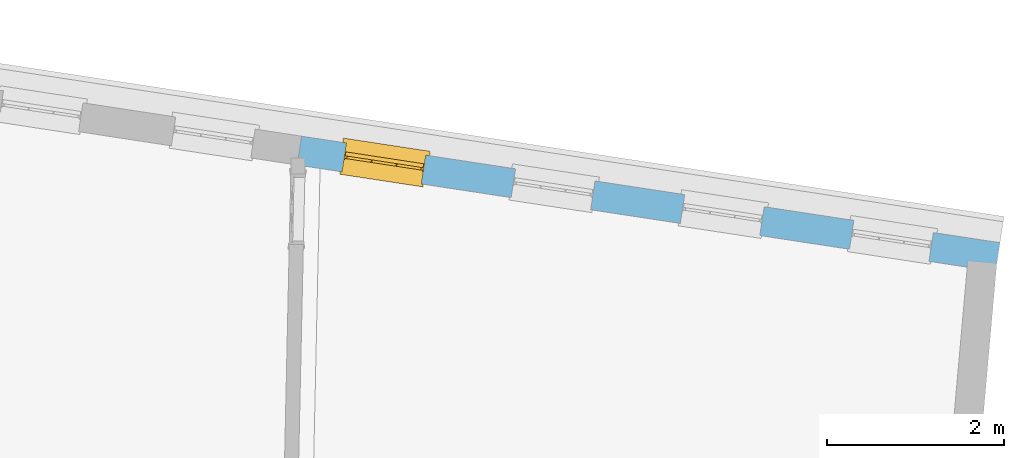
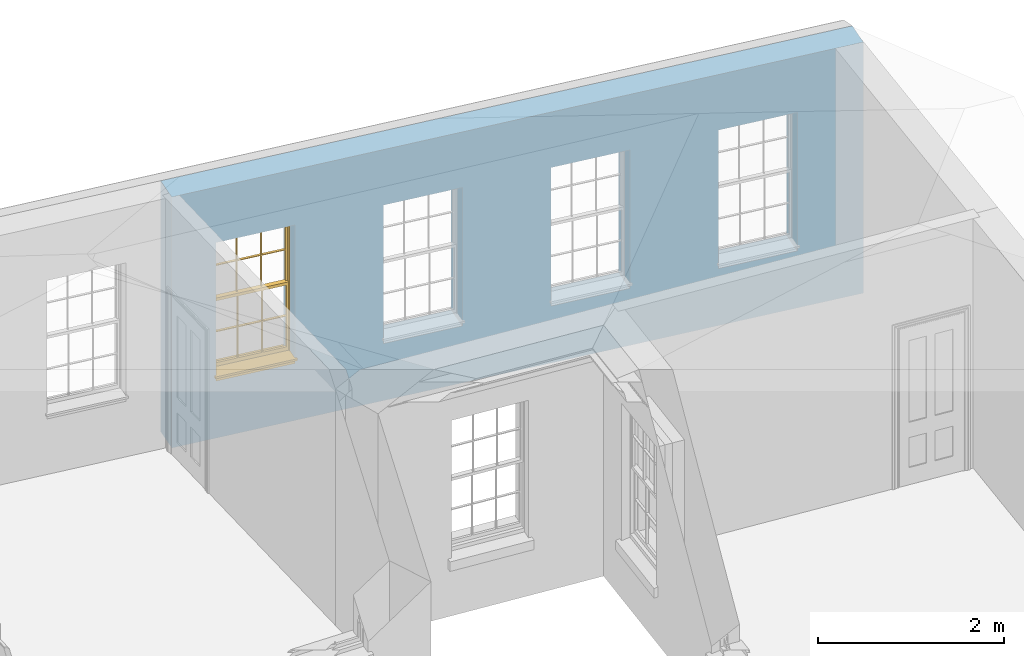
# One storey, part 10 of 12: 1 window, 4 openings, plus 1 element that does not belong to this part.
"""IFC2X3 building model written with IfcOpenShell, lengths in metres."""

from ifc_helpers import new_model, si_unit, frame, origin, place, context, subcontext, project, spatial, polyline, outline, extrude, faceted_brep, material, layer, layer_set, layer_usage, element, fill, save


model = new_model("IFC2X3")

# Units and contexts
model_context = context("Model", 3, world=origin())
body_context = subcontext(model_context, "Body", "Model", "MODEL_VIEW")
ifc_project = project(units=[si_unit("PLANEANGLEUNIT", "RADIAN"), si_unit("MASSUNIT", "GRAM", prefix="KILO"), si_unit("FORCEUNIT", "NEWTON", prefix="KILO"), si_unit("LENGTHUNIT", "METRE")], contexts=[model_context])

# Site, building, storey
site_placement = place(None, origin())
site = spatial("IfcSite", under=ifc_project, at=site_placement, CompositionType="ELEMENT")
building_placement = place(None, origin())
building = spatial("IfcBuilding", under=site, at=building_placement, Name="Building plot-18", CompositionType="ELEMENT")
storey_placement = place(None, frame((0.0, 0.0, 9.9)))
storey = spatial("IfcBuildingStorey", under=building, at=storey_placement, Name="Floor 2", CompositionType="ELEMENT", Elevation=9.9)

# Wall, openings, window
ifc_material = material(Name="Masonry")
ifc_layer = layer(ifc_material, 0.33, ventilated=False)
ifc_layer_set = layer_set([ifc_layer], Name="My Wall")
ifc_layer_usage = layer_usage(ifc_layer_set, "AXIS2", "NEGATIVE", 0.08)
wall_placement = place(storey_placement, origin())
wall = element("IfcWallStandardCase", 1, at=wall_placement, inside=storey, material=ifc_layer_usage, Name="exterior", context=body_context, shape_type="SweptSolid", body=[
    extrude(outline(polyline([(101.941775393575, 24.4390124661107), (101.991519769301, 24.7652416755381), (94.0844961381432, 25.9709275645287), (94.0347517624171, 25.6446983551013), (101.941775393575, 24.4390124661107)])), origin(), (0.0, 0.0, 1.0), 3.3),
])
opening_1_placement = place(storey_placement, frame((0.0, 0.0, 0.75)))
element("IfcOpeningElement", 2, at=opening_1_placement, cuts=wall, Name="Opening", ObjectType="Opening", context=body_context, shape_type="SweptSolid", body=[
    extrude(outline(polyline([(101.236692272156, 24.880339960858), (100.337090512825, 25.017513845436), (100.287346137099, 24.6912846360086), (101.186947896429, 24.5541107514306), (101.236692272156, 24.880339960858)])), origin(), (0.0, 0.0, 1.0), 1.82),
])
opening_2_placement = place(storey_placement, frame((0.0, 0.0, 0.75)))
element("IfcOpeningElement", 3, at=opening_2_placement, cuts=wall, Name="Opening", ObjectType="Opening", context=body_context, shape_type="SweptSolid", body=[
    extrude(outline(polyline([(99.3217221994849, 25.1723401498242), (98.4221204401548, 25.3095140344022), (98.3723760644287, 24.9832848249748), (99.2719778237588, 24.8461109403968), (99.3217221994849, 25.1723401498242)])), origin(), (0.0, 0.0, 1.0), 1.82),
])
opening_3_placement = place(storey_placement, frame((0.0, 0.0, 0.75)))
element("IfcOpeningElement", 4, at=opening_3_placement, cuts=wall, Name="Opening", ObjectType="Opening", context=body_context, shape_type="SweptSolid", body=[
    extrude(outline(polyline([(97.4067521268142, 25.4643403387904), (96.5071503674841, 25.6015142233684), (96.4574059917581, 25.275285013941), (97.3570077510882, 25.138111129363), (97.4067521268142, 25.4643403387904)])), origin(), (0.0, 0.0, 1.0), 1.82),
])
opening_4_placement = place(storey_placement, frame((0.0, 0.0, 0.75)))
opening_4 = element("IfcOpeningElement", 5, at=opening_4_placement, cuts=wall, Name="Opening", ObjectType="Opening", context=body_context, shape_type="SweptSolid", body=[
    extrude(outline(polyline([(95.4917820541436, 25.7563405277566), (94.5921802948135, 25.8935144123346), (94.5424359190874, 25.5672852029072), (95.4420376784175, 25.4301113183292), (95.4917820541436, 25.7563405277566)])), origin(), (0.0, 0.0, 1.0), 1.82),
])
window_placement = place(storey_placement, frame((95.4540969210178, 25.5091971872813, 0.75), z_axis=(0.0, 0.0, 1.0), x_axis=(-0.899601759330096, 0.13717388457793, 0.0)))
window = element("IfcWindow", 6, at=window_placement, inside=storey, Name="circulation outside window", OverallHeight=1.82, OverallWidth=0.91, context=body_context, shape_type="Brep", held_by="IfcProductRepresentation", body=[
    faceted_brep([(0.033125, -0.105, 0.975209), (0.01, -0.105, 0.975209), (0.033125, -0.105, 1.376042), (0.876875, -0.105, 0.975209), (0.876875, -0.105, 1.376042), (0.9, -0.105, 0.975209), (0.876875, -0.105, 1.386042), (0.876875, -0.105, 1.786875), (0.9, -0.105, 1.81), (0.033125, -0.105, 1.786875), (0.033125, -0.105, 1.386042), (0.01, -0.105, 1.81), (0.876875, -0.135, 1.376042), (0.876875, -0.135, 0.975209), (0.9, -0.135, 0.937083), (0.033125, -0.135, 1.786875), (0.01, -0.135, 1.81), (0.033125, -0.135, 1.386042), (0.01, -0.135, 0.937083), (0.033125, -0.135, 0.975209), (0.033125, -0.135, 1.376042), (0.876875, -0.135, 1.786875), (0.876875, -0.135, 1.386042), (0.9, -0.135, 1.81), (0.033125, -0.105, 0.937083), (0.01, -0.105, 0.937083), (0.033125, -0.105, 0.53625), (0.876875, -0.105, 0.937083), (0.876875, -0.105, 0.53625), (0.9, -0.105, 0.937083), (0.876875, -0.105, 0.52625), (0.876875, -0.105, 0.125417), (0.9, -0.105, 0.077167), (0.033125, -0.105, 0.125417), (0.033125, -0.105, 0.52625), (0.01, -0.105, 0.077167), (-0.0425, -0.25, 0.01), (-0.0425, -0.3, 0.001667), (0.0, -0.25, 0.01), (0.9525, -0.25, 0.01), (0.91, -0.25, 0.01), (0.9525, -0.3, 0.001667), (-0.02, 0.08, 0.077167), (0.0, 0.08, 0.077167), (-0.02, 0.11, 0.077167), (0.0, -0.06, 0.077167), (0.01, -0.06, 0.077167), (0.91, -0.06, 0.077167), (0.91, 0.08, 0.077167), (0.9, -0.06, 0.077167), (0.93, 0.08, 0.077167), (0.93, 0.11, 0.077167), (0.01, -0.075, 0.975209), (0.9, -0.075, 0.975209), (0.876875, -0.075, 0.125417), (0.876875, -0.075, 0.52625), (0.9, -0.075, 0.077167), (0.876875, -0.075, 0.53625), (0.876875, -0.075, 0.937083), (0.033125, -0.075, 0.125417), (0.01, -0.075, 0.077167), (0.033125, -0.075, 0.52625), (0.033125, -0.075, 0.937083), (0.033125, -0.075, 0.53625), (-0.02, 0.08, 0.052167), (-0.02, 0.11, 0.052167), (0.93, 0.11, 0.052167), (0.93, 0.08, 0.052167), (0.91, 0.08, 0.052167), (0.0, 0.08, 0.052167), (0.91, -0.15, 0.026667), (0.0, -0.15, 0.026667), (-0.0425, -0.3, -0.123333), (0.9525, -0.3, -0.123333), (-0.0425, -0.25, -0.123333), (0.9525, -0.25, -0.123333), (0.01, -0.06, 1.81), (0.9, -0.06, 1.81), (0.0, -0.06, 1.82), (0.91, -0.06, 1.82), (0.01, -0.15, 0.077167), (0.9, -0.15, 0.077167), (0.592292, -0.105, 0.125417), (0.592292, -0.075, 0.125417), (0.317708, -0.075, 0.125417), (0.317708, -0.105, 0.125417), (0.592292, -0.105, 0.53625), (0.317708, -0.105, 0.53625), (0.317708, -0.105, 0.52625), (0.592292, -0.105, 0.52625), (0.592292, -0.075, 0.53625), (0.317708, -0.075, 0.53625), (0.592292, -0.135, 1.386042), (0.592292, -0.105, 1.386042), (0.317708, -0.105, 1.386042), (0.317708, -0.135, 1.386042), (0.317708, -0.135, 1.376042), (0.592292, -0.135, 1.376042), (0.317708, -0.105, 1.376042), (0.592292, -0.105, 1.376042), (0.602292, -0.135, 1.376042), (0.592292, -0.135, 0.975209), (0.602292, -0.135, 0.975209), (0.602292, -0.105, 0.975209), (0.592292, -0.105, 0.975209), (0.602292, -0.105, 1.376042), (0.602292, -0.075, 0.53625), (0.602292, -0.105, 0.53625), (0.317708, -0.075, 0.52625), (0.307708, -0.075, 0.125417), (0.307708, -0.075, 0.52625), (0.602292, -0.075, 0.52625), (0.602292, -0.075, 0.125417), (0.592292, -0.075, 0.52625), (0.307708, -0.075, 0.53625), (0.317708, -0.075, 0.937083), (0.307708, -0.075, 0.937083), (0.602292, -0.075, 0.937083), (0.592292, -0.075, 0.937083), (0.307708, -0.105, 0.52625), (0.307708, -0.105, 0.125417), (0.307708, -0.105, 0.53625), (0.307708, -0.105, 0.937083), (0.592292, -0.105, 0.937083), (0.317708, -0.105, 0.937083), (0.602292, -0.105, 0.937083), (0.602292, -0.105, 0.52625), (0.602292, -0.105, 0.125417), (0.307708, -0.135, 1.386042), (0.307708, -0.135, 1.376042), (0.307708, -0.135, 0.975209), (0.317708, -0.135, 0.975209), (0.317708, -0.135, 1.786875), (0.307708, -0.135, 1.786875), (0.602292, -0.135, 1.786875), (0.592292, -0.135, 1.786875), (0.602292, -0.135, 1.386042), (0.602292, -0.105, 1.386042), (0.307708, -0.105, 1.386042), (0.307708, -0.105, 1.786875), (0.317708, -0.105, 1.786875), (0.592292, -0.105, 1.786875), (0.602292, -0.105, 1.786875), (0.307708, -0.105, 1.376042), (0.317708, -0.105, 0.975209), (0.307708, -0.105, 0.975209), (0.91, -0.15, 1.82), (0.9, -0.15, 1.81), (0.01, -0.15, 1.81), (0.0, -0.15, 1.82), (0.91, -0.25, 0.0), (0.0, -0.25, 0.0), (0.91, 0.08, 0.0), (0.0, 0.08, 0.0)], [[[0, 1, 2]], [[3, 4, 5]], [[6, 7, 8]], [[9, 10, 11]], [[12, 13, 14]], [[15, 16, 17]], [[18, 19, 20]], [[21, 22, 23]], [[24, 25, 26]], [[27, 28, 29]], [[30, 31, 32]], [[33, 34, 35]], [[14, 27, 29]], [[25, 24, 18]], [[36, 37, 38]], [[39, 40, 41]], [[42, 43, 44]], [[45, 46, 43]], [[47, 48, 49]], [[50, 51, 48]], [[1, 0, 52]], [[5, 53, 3]], [[54, 55, 56]], [[57, 58, 53]], [[59, 60, 61]], [[62, 63, 52]], [[48, 43, 46, 49]], [[51, 44, 43, 48]], [[64, 42, 44, 65]], [[65, 44, 51, 66]], [[66, 51, 50, 67]], [[65, 66, 68, 69]], [[60, 56, 49, 46]], [[70, 71, 38, 40]], [[37, 41, 40, 38]], [[37, 72, 73, 41]], [[74, 75, 73, 72]], [[8, 11, 76, 77]], [[76, 78, 79, 77]], [[32, 35, 80, 81]], [[81, 80, 71, 70]], [[82, 83, 84, 85]], [[86, 87, 88, 89]], [[86, 90, 91, 87]], [[92, 93, 94, 95]], [[92, 95, 96, 97]], [[96, 98, 99, 97]], [[100, 97, 101, 102]], [[103, 104, 99, 105]], [[97, 99, 104, 101]], [[102, 103, 105, 100]], [[28, 57, 106, 107]], [[108, 84, 109, 110]], [[111, 112, 83, 113]], [[114, 110, 61, 63]], [[90, 113, 108, 91]], [[115, 91, 114, 116]], [[117, 106, 90, 118]], [[111, 106, 57, 55]], [[119, 110, 109, 120]], [[34, 61, 110, 119]], [[89, 113, 83, 82]], [[88, 108, 113, 89]], [[85, 84, 108, 88]], [[121, 114, 63, 26]], [[122, 116, 114, 121]], [[123, 118, 90, 86]], [[87, 91, 115, 124]], [[107, 106, 117, 125]], [[126, 111, 55, 30]], [[127, 112, 111, 126]], [[126, 30, 28, 107]], [[88, 119, 120, 85]], [[126, 89, 82, 127]], [[125, 123, 86, 107]], [[121, 26, 34, 119]], [[124, 122, 121, 87]], [[128, 17, 20, 129]], [[96, 129, 130, 131]], [[132, 133, 128, 95]], [[134, 135, 92, 136]], [[100, 12, 22, 136]], [[137, 6, 4, 105]], [[94, 138, 139, 140]], [[137, 93, 141, 142]], [[99, 98, 94, 93]], [[143, 2, 10, 138]], [[144, 145, 143, 98]], [[129, 143, 145, 130]], [[20, 2, 143, 129]], [[131, 144, 98, 96]], [[128, 138, 10, 17]], [[133, 139, 138, 128]], [[135, 141, 93, 92]], [[95, 94, 140, 132]], [[22, 6, 137, 136]], [[136, 137, 142, 134]], [[100, 105, 4, 12]], [[107, 86, 89, 126]], [[106, 111, 113, 90]], [[91, 108, 110, 114]], [[87, 121, 119, 88]], [[97, 100, 136, 92]], [[129, 96, 95, 128]], [[98, 143, 138, 94]], [[105, 99, 93, 137]], [[131, 101, 104, 144]], [[124, 115, 118, 123]], [[132, 140, 141, 135]], [[120, 109, 59, 33]], [[15, 9, 139, 133]], [[134, 142, 7, 21]], [[31, 54, 112, 127]], [[36, 74, 72, 37]], [[39, 41, 73, 75]], [[18, 14, 101, 131]], [[23, 16, 132, 135]], [[83, 56, 60, 84]], [[52, 53, 118, 115]], [[53, 52, 144, 104]], [[11, 8, 141, 140]], [[14, 18, 124, 123]], [[2, 1, 11, 10]], [[8, 5, 4, 6]], [[57, 53, 56, 55]], [[60, 52, 63, 61]], [[26, 25, 35, 34]], [[32, 29, 28, 30]], [[14, 23, 22, 12]], [[18, 20, 17, 16]], [[19, 0, 2, 20]], [[17, 10, 9, 15]], [[12, 4, 3, 13]], [[21, 7, 6, 22]], [[27, 58, 57, 28]], [[30, 55, 54, 31]], [[33, 59, 61, 34]], [[26, 63, 62, 24]], [[5, 8, 77, 53]], [[76, 11, 1, 52]], [[46, 45, 78, 76]], [[49, 77, 79, 47]], [[70, 146, 147, 81]], [[71, 80, 148, 149]], [[19, 130, 145, 0]], [[102, 13, 3, 103]], [[116, 122, 24, 62]], [[29, 32, 81, 14]], [[80, 35, 25, 18]], [[60, 46, 76, 52]], [[77, 49, 56, 53]], [[23, 14, 81, 147]], [[16, 148, 80, 18]], [[35, 85, 120]], [[120, 33, 35]], [[127, 82, 32]], [[32, 31, 127]], [[32, 82, 85, 35]], [[102, 101, 14]], [[14, 13, 102]], [[18, 131, 130]], [[130, 19, 18]], [[134, 21, 23]], [[23, 135, 134]], [[16, 15, 133]], [[133, 132, 16]], [[11, 140, 139]], [[139, 9, 11]], [[142, 141, 8]], [[8, 7, 142]], [[23, 147, 148, 16]], [[146, 149, 148, 147]], [[52, 115, 116]], [[116, 62, 52]], [[118, 53, 117]], [[58, 117, 53]], [[27, 125, 117, 58]], [[56, 83, 112]], [[112, 54, 56]], [[109, 84, 60]], [[60, 59, 109]], [[125, 27, 14]], [[14, 123, 125]], [[122, 124, 18]], [[18, 24, 122]], [[145, 144, 52]], [[52, 0, 145]], [[103, 3, 53]], [[53, 104, 103]], [[79, 78, 149, 146]], [[78, 45, 71, 149]], [[146, 70, 47, 79]], [[150, 75, 74, 151]], [[68, 66, 67]], [[48, 68, 67, 50]], [[69, 64, 65]], [[42, 64, 69, 43]], [[69, 68, 152, 153]], [[70, 68, 48, 47]], [[150, 152, 68, 70]], [[43, 69, 71, 45]], [[69, 153, 151, 71]], [[152, 150, 151, 153]], [[38, 151, 74, 36]], [[71, 151, 38]], [[39, 75, 150, 40]], [[40, 150, 70]]]),
])
fill(opening_4, window)

save(model, "model.ifc")
